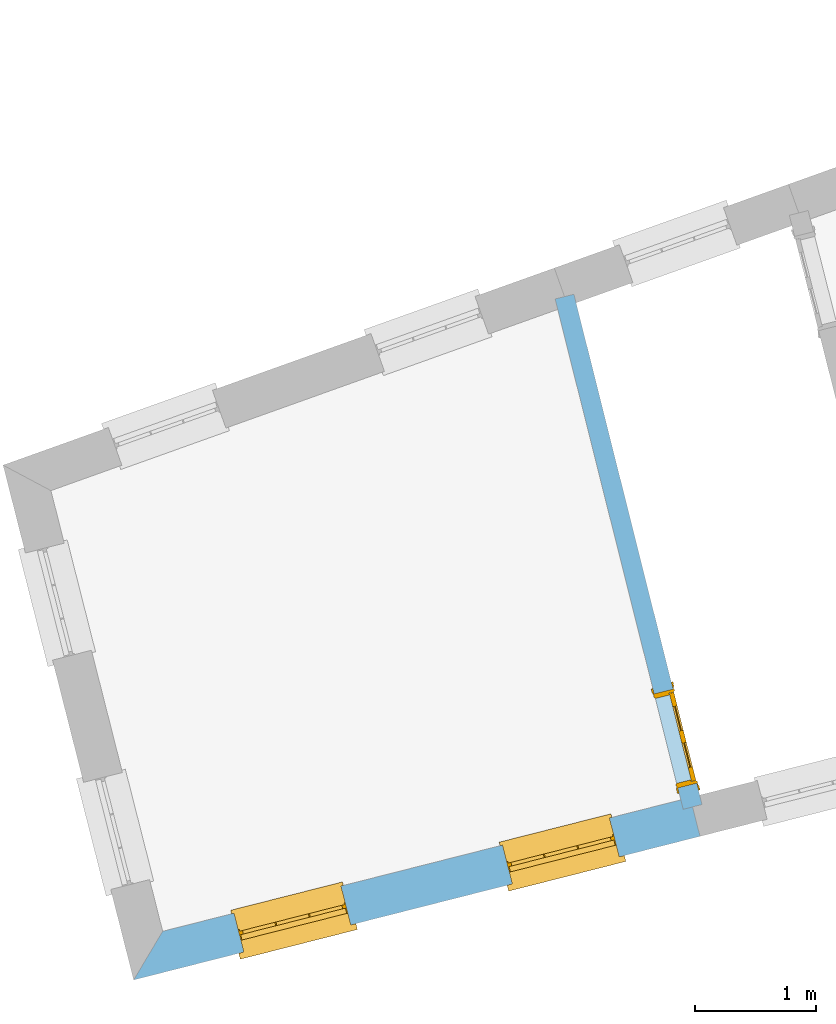
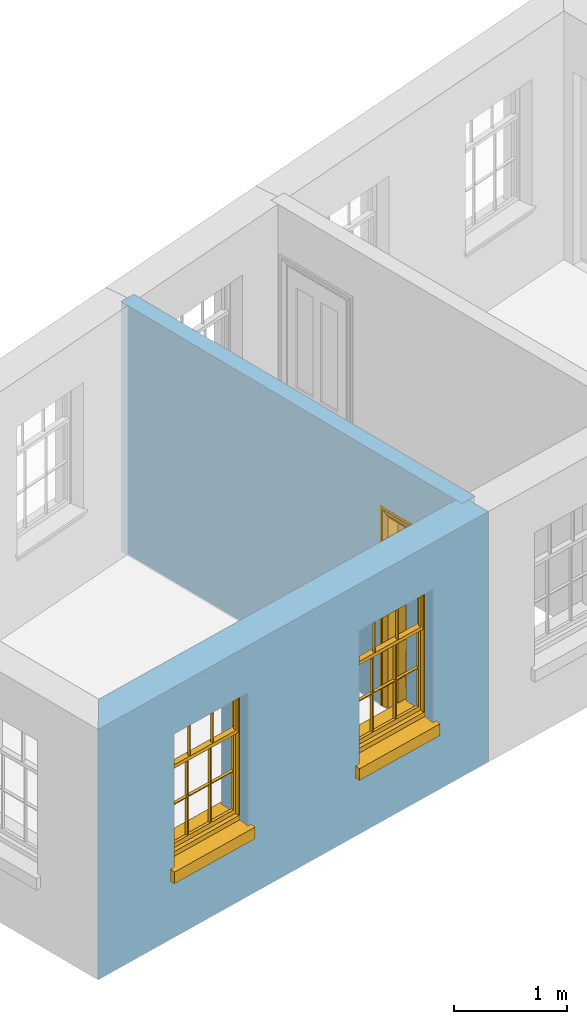
# One storey, part 3 of 10: 2 windows, 1 door, 3 openings, plus 2 elements that do not belong to this part.
"""IFC2X3 building model written with IfcOpenShell, lengths in metres."""

from ifc_helpers import new_model, si_unit, frame, origin, place, context, subcontext, project, spatial, polyline, outline, extrude, faceted_brep, material, layer, layer_set, layer_usage, element, fill, save


model = new_model("IFC2X3")

# Units and contexts
model_context = context("Model", 3, world=origin())
body_context = subcontext(model_context, "Body", "Model", "MODEL_VIEW")
ifc_project = project(units=[si_unit("PLANEANGLEUNIT", "RADIAN"), si_unit("MASSUNIT", "GRAM", prefix="KILO"), si_unit("FORCEUNIT", "NEWTON", prefix="KILO"), si_unit("LENGTHUNIT", "METRE")], contexts=[model_context])

# Site, building, storey
site_placement = place(None, origin())
site = spatial("IfcSite", under=ifc_project, at=site_placement, CompositionType="ELEMENT")
building_placement = place(None, origin())
building = spatial("IfcBuilding", under=site, at=building_placement, Name="Building plot-13", CompositionType="ELEMENT")
storey_placement = place(None, frame((0.0, 0.0, 9.55)))
storey = spatial("IfcBuildingStorey", under=building, at=storey_placement, Name="Floor 2", CompositionType="ELEMENT", Elevation=9.55)

# Wall, openings, windows
ifc_material_1 = material(Name="Masonry")
ifc_layer_1 = layer(ifc_material_1, 0.33, ventilated=False)
ifc_layer_set_1 = layer_set([ifc_layer_1], Name="My Wall")
ifc_layer_usage_1 = layer_usage(ifc_layer_set_1, "AXIS2", "NEGATIVE", 0.08)
wall_1_placement = place(storey_placement, origin())
wall_1 = element("IfcWallStandardCase", 1, at=wall_1_placement, inside=storey, material=ifc_layer_usage_1, Name="exterior", context=body_context, shape_type="SweptSolid", body=[
    extrude(outline(polyline([(66.8267058597151, 43.9122434030099), (66.5879619422004, 43.5112429767636), (71.2509007169492, 44.6938906600119), (71.1697724625834, 45.0137628318924), (66.8267058597151, 43.9122434030099)])), origin(), (0.0, 0.0, 1.0), 2.7),
])
opening_1_placement = place(storey_placement, frame((0.0, 0.0, 0.75)))
opening_1 = element("IfcOpeningElement", 2, at=opening_1_placement, cuts=wall_1, Name="Opening", ObjectType="Opening", context=body_context, shape_type="SweptSolid", body=[
    extrude(outline(polyline([(67.494406314742, 43.7411418429004), (68.3764780614428, 43.964859150394), (68.295349807077, 44.2847313222745), (67.4132780603762, 44.0610140147809), (67.494406314742, 43.7411418429004)])), origin(), (0.0, 0.0, 1.0), 1.445),
])
opening_2_placement = place(storey_placement, frame((0.0, 0.0, 0.75)))
opening_2 = element("IfcOpeningElement", 3, at=opening_2_placement, cuts=wall_1, Name="Opening", ObjectType="Opening", context=body_context, shape_type="SweptSolid", body=[
    extrude(outline(polyline([(69.7047120006465, 44.3017352851435), (70.5867837473473, 44.5254525926372), (70.5056554929815, 44.8453247645177), (69.6235837462807, 44.621607457024), (69.7047120006465, 44.3017352851435)])), origin(), (0.0, 0.0, 1.0), 1.445),
])
window_1_placement = place(storey_placement, frame((67.4329455159801, 43.9834692458402, 0.75), z_axis=(0.0, 0.0, 1.0), x_axis=(0.882071746700802, 0.223717307493636, 0.0)))
window_1 = element("IfcWindow", 4, at=window_1_placement, inside=storey, Name="bedroom outside window", OverallHeight=1.445, OverallWidth=0.91, context=body_context, shape_type="Brep", held_by="IfcProductRepresentation", body=[
    faceted_brep([(0.876875, -0.105, 0.999097), (0.876875, -0.105, 1.411875), (0.9, -0.105, 1.435), (0.033125, -0.105, 1.411875), (0.033125, -0.105, 0.999097), (0.01, -0.105, 1.435), (0.033125, -0.135, 1.411875), (0.01, -0.135, 1.435), (0.033125, -0.135, 0.999097), (0.876875, -0.135, 1.411875), (0.876875, -0.135, 0.999097), (0.9, -0.135, 1.435), (0.033125, -0.105, 0.960972), (0.01, -0.105, 0.960972), (0.033125, -0.105, 0.548195), (0.876875, -0.105, 0.960972), (0.876875, -0.105, 0.548195), (0.9, -0.105, 0.960972), (0.876875, -0.105, 0.538195), (0.876875, -0.105, 0.125417), (0.9, -0.105, 0.077167), (0.033125, -0.105, 0.125417), (0.033125, -0.105, 0.538195), (0.01, -0.105, 0.077167), (0.9, -0.135, 0.960972), (0.01, -0.135, 0.960972), (-0.0425, -0.25, 0.01), (-0.0425, -0.3, 0.001667), (0.0, -0.25, 0.01), (0.9525, -0.25, 0.01), (0.91, -0.25, 0.01), (0.9525, -0.3, 0.001667), (-0.02, 0.08, 0.077167), (0.0, 0.08, 0.077167), (-0.02, 0.11, 0.077167), (0.0, -0.06, 0.077167), (0.01, -0.06, 0.077167), (0.91, -0.06, 0.077167), (0.91, 0.08, 0.077167), (0.9, -0.06, 0.077167), (0.93, 0.08, 0.077167), (0.93, 0.11, 0.077167), (0.01, -0.105, 0.999097), (0.01, -0.075, 0.999097), (0.9, -0.105, 0.999097), (0.9, -0.075, 0.999097), (0.876875, -0.075, 0.125417), (0.876875, -0.075, 0.538195), (0.9, -0.075, 0.077167), (0.876875, -0.075, 0.548195), (0.876875, -0.075, 0.960972), (0.033125, -0.075, 0.125417), (0.01, -0.075, 0.077167), (0.033125, -0.075, 0.538195), (0.033125, -0.075, 0.960972), (0.033125, -0.075, 0.548195), (-0.02, 0.08, 0.052167), (-0.02, 0.11, 0.052167), (0.93, 0.11, 0.052167), (0.93, 0.08, 0.052167), (0.91, 0.08, 0.052167), (0.0, 0.08, 0.052167), (0.91, -0.15, 0.026667), (0.0, -0.15, 0.026667), (-0.0425, -0.3, -0.123333), (0.9525, -0.3, -0.123333), (-0.0425, -0.25, -0.123333), (0.9525, -0.25, -0.123333), (0.01, -0.06, 1.435), (0.9, -0.06, 1.435), (0.0, -0.06, 1.445), (0.91, -0.06, 1.445), (0.01, -0.15, 0.077167), (0.9, -0.15, 0.077167), (0.592292, -0.105, 0.125417), (0.592292, -0.075, 0.125417), (0.317708, -0.075, 0.125417), (0.317708, -0.105, 0.125417), (0.592292, -0.105, 0.548195), (0.317708, -0.105, 0.548195), (0.317708, -0.105, 0.538195), (0.592292, -0.105, 0.538195), (0.592292, -0.075, 0.548195), (0.317708, -0.075, 0.548195), (0.602292, -0.075, 0.548195), (0.602292, -0.105, 0.548195), (0.317708, -0.075, 0.538195), (0.307708, -0.075, 0.125417), (0.307708, -0.075, 0.538195), (0.602292, -0.075, 0.538195), (0.602292, -0.075, 0.125417), (0.592292, -0.075, 0.538195), (0.307708, -0.075, 0.548195), (0.317708, -0.075, 0.960972), (0.307708, -0.075, 0.960972), (0.602292, -0.075, 0.960972), (0.592292, -0.075, 0.960972), (0.307708, -0.105, 0.538195), (0.307708, -0.105, 0.125417), (0.307708, -0.105, 0.548195), (0.307708, -0.105, 0.960972), (0.592292, -0.105, 0.960972), (0.317708, -0.105, 0.960972), (0.602292, -0.105, 0.960972), (0.602292, -0.105, 0.538195), (0.602292, -0.105, 0.125417), (0.317708, -0.135, 1.411875), (0.307708, -0.135, 1.411875), (0.307708, -0.135, 0.999097), (0.317708, -0.135, 0.999097), (0.602292, -0.135, 1.411875), (0.592292, -0.135, 1.411875), (0.592292, -0.135, 0.999097), (0.602292, -0.135, 0.999097), (0.317708, -0.105, 0.999097), (0.307708, -0.105, 0.999097), (0.307708, -0.105, 1.411875), (0.317708, -0.105, 1.411875), (0.602292, -0.105, 0.999097), (0.592292, -0.105, 0.999097), (0.592292, -0.105, 1.411875), (0.602292, -0.105, 1.411875), (0.91, -0.15, 1.445), (0.9, -0.15, 1.435), (0.01, -0.15, 1.435), (0.0, -0.15, 1.445), (0.91, -0.25, 0.0), (0.0, -0.25, 0.0), (0.91, 0.08, 0.0), (0.0, 0.08, 0.0)], [[[0, 1, 2]], [[3, 4, 5]], [[6, 7, 8]], [[9, 10, 11]], [[12, 13, 14]], [[15, 16, 17]], [[18, 19, 20]], [[21, 22, 23]], [[24, 15, 17]], [[13, 12, 25]], [[26, 27, 28]], [[29, 30, 31]], [[32, 33, 34]], [[35, 36, 33]], [[37, 38, 39]], [[40, 41, 38]], [[42, 4, 43]], [[44, 45, 0]], [[46, 47, 48]], [[49, 50, 45]], [[51, 52, 53]], [[54, 55, 43]], [[38, 33, 36, 39]], [[41, 34, 33, 38]], [[56, 32, 34, 57]], [[57, 34, 41, 58]], [[58, 41, 40, 59]], [[57, 58, 60, 61]], [[52, 48, 39, 36]], [[62, 63, 28, 30]], [[27, 31, 30, 28]], [[27, 64, 65, 31]], [[66, 67, 65, 64]], [[2, 5, 68, 69]], [[68, 70, 71, 69]], [[20, 23, 72, 73]], [[73, 72, 63, 62]], [[74, 75, 76, 77]], [[78, 79, 80, 81]], [[78, 82, 83, 79]], [[16, 49, 84, 85]], [[86, 76, 87, 88]], [[89, 90, 75, 91]], [[92, 88, 53, 55]], [[82, 91, 86, 83]], [[93, 83, 92, 94]], [[95, 84, 82, 96]], [[89, 84, 49, 47]], [[97, 88, 87, 98]], [[22, 53, 88, 97]], [[81, 91, 75, 74]], [[80, 86, 91, 81]], [[77, 76, 86, 80]], [[99, 92, 55, 14]], [[100, 94, 92, 99]], [[101, 96, 82, 78]], [[79, 83, 93, 102]], [[85, 84, 95, 103]], [[104, 89, 47, 18]], [[105, 90, 89, 104]], [[104, 18, 16, 85]], [[80, 97, 98, 77]], [[104, 81, 74, 105]], [[103, 101, 78, 85]], [[99, 14, 22, 97]], [[102, 100, 99, 79]], [[106, 107, 108, 109]], [[110, 111, 112, 113]], [[114, 115, 116, 117]], [[118, 119, 120, 121]], [[107, 116, 115, 108]], [[111, 120, 119, 112]], [[109, 114, 117, 106]], [[113, 118, 121, 110]], [[85, 78, 81, 104]], [[84, 89, 91, 82]], [[83, 86, 88, 92]], [[79, 99, 97, 80]], [[109, 112, 119, 114]], [[102, 93, 96, 101]], [[106, 117, 120, 111]], [[98, 87, 51, 21]], [[6, 3, 116, 107]], [[110, 121, 1, 9]], [[19, 46, 90, 105]], [[26, 66, 64, 27]], [[29, 31, 65, 67]], [[25, 24, 112, 109]], [[11, 7, 106, 111]], [[75, 48, 52, 76]], [[43, 45, 96, 93]], [[45, 43, 114, 119]], [[5, 2, 120, 117]], [[24, 25, 102, 101]], [[42, 5, 4]], [[2, 44, 0]], [[49, 45, 48, 47]], [[52, 43, 55, 53]], [[14, 13, 23, 22]], [[20, 17, 16, 18]], [[24, 11, 10]], [[25, 8, 7]], [[8, 4, 3, 6]], [[9, 1, 0, 10]], [[15, 50, 49, 16]], [[18, 47, 46, 19]], [[21, 51, 53, 22]], [[14, 55, 54, 12]], [[44, 2, 69, 45]], [[68, 5, 42, 43]], [[36, 35, 70, 68]], [[39, 69, 71, 37]], [[62, 122, 123, 73]], [[63, 72, 124, 125]], [[8, 108, 115, 4]], [[113, 10, 0, 118]], [[94, 100, 12, 54]], [[17, 20, 73, 24]], [[72, 23, 13, 25]], [[52, 36, 68, 43]], [[69, 39, 48, 45]], [[11, 24, 73, 123]], [[7, 124, 72, 25]], [[23, 77, 98]], [[98, 21, 23]], [[105, 74, 20]], [[20, 19, 105]], [[20, 74, 77, 23]], [[113, 112, 24]], [[24, 10, 113]], [[25, 109, 108]], [[108, 8, 25]], [[110, 9, 11]], [[11, 111, 110]], [[7, 6, 107]], [[107, 106, 7]], [[5, 117, 116]], [[116, 3, 5]], [[121, 120, 2]], [[2, 1, 121]], [[11, 123, 124, 7]], [[122, 125, 124, 123]], [[43, 93, 94]], [[94, 54, 43]], [[96, 45, 95]], [[50, 95, 45]], [[15, 103, 95, 50]], [[48, 75, 90]], [[90, 46, 48]], [[87, 76, 52]], [[52, 51, 87]], [[103, 15, 24]], [[24, 101, 103]], [[100, 102, 25]], [[25, 12, 100]], [[115, 114, 43]], [[43, 4, 115]], [[118, 0, 45]], [[45, 119, 118]], [[71, 70, 125, 122]], [[70, 35, 63, 125]], [[122, 62, 37, 71]], [[126, 67, 66, 127]], [[60, 58, 59]], [[38, 60, 59, 40]], [[61, 56, 57]], [[32, 56, 61, 33]], [[61, 60, 128, 129]], [[62, 60, 38, 37]], [[126, 128, 60, 62]], [[33, 61, 63, 35]], [[61, 129, 127, 63]], [[128, 126, 127, 129]], [[28, 127, 66, 26]], [[63, 127, 28]], [[29, 67, 126, 30]], [[30, 126, 62]]]),
])
fill(opening_1, window_1)
window_2_placement = place(storey_placement, frame((69.6432512018846, 44.5440626880833, 0.75), z_axis=(0.0, 0.0, 1.0), x_axis=(0.882071746700802, 0.223717307493636, 0.0)))
window_2 = element("IfcWindow", 5, at=window_2_placement, inside=storey, Name="bedroom outside window", OverallHeight=1.445, OverallWidth=0.91, context=body_context, shape_type="Brep", held_by="IfcProductRepresentation", body=[
    faceted_brep([(0.876875, -0.105, 0.999097), (0.876875, -0.105, 1.411875), (0.9, -0.105, 1.435), (0.033125, -0.105, 1.411875), (0.033125, -0.105, 0.999097), (0.01, -0.105, 1.435), (0.033125, -0.135, 1.411875), (0.01, -0.135, 1.435), (0.033125, -0.135, 0.999097), (0.876875, -0.135, 1.411875), (0.876875, -0.135, 0.999097), (0.9, -0.135, 1.435), (0.033125, -0.105, 0.960972), (0.01, -0.105, 0.960972), (0.033125, -0.105, 0.548195), (0.876875, -0.105, 0.960972), (0.876875, -0.105, 0.548195), (0.9, -0.105, 0.960972), (0.876875, -0.105, 0.538195), (0.876875, -0.105, 0.125417), (0.9, -0.105, 0.077167), (0.033125, -0.105, 0.125417), (0.033125, -0.105, 0.538195), (0.01, -0.105, 0.077167), (0.9, -0.135, 0.960972), (0.01, -0.135, 0.960972), (-0.0425, -0.25, 0.01), (-0.0425, -0.3, 0.001667), (0.0, -0.25, 0.01), (0.9525, -0.25, 0.01), (0.91, -0.25, 0.01), (0.9525, -0.3, 0.001667), (-0.02, 0.08, 0.077167), (0.0, 0.08, 0.077167), (-0.02, 0.11, 0.077167), (0.0, -0.06, 0.077167), (0.01, -0.06, 0.077167), (0.91, -0.06, 0.077167), (0.91, 0.08, 0.077167), (0.9, -0.06, 0.077167), (0.93, 0.08, 0.077167), (0.93, 0.11, 0.077167), (0.01, -0.105, 0.999097), (0.01, -0.075, 0.999097), (0.9, -0.105, 0.999097), (0.9, -0.075, 0.999097), (0.876875, -0.075, 0.125417), (0.876875, -0.075, 0.538195), (0.9, -0.075, 0.077167), (0.876875, -0.075, 0.548195), (0.876875, -0.075, 0.960972), (0.033125, -0.075, 0.125417), (0.01, -0.075, 0.077167), (0.033125, -0.075, 0.538195), (0.033125, -0.075, 0.960972), (0.033125, -0.075, 0.548195), (-0.02, 0.08, 0.052167), (-0.02, 0.11, 0.052167), (0.93, 0.11, 0.052167), (0.93, 0.08, 0.052167), (0.91, 0.08, 0.052167), (0.0, 0.08, 0.052167), (0.91, -0.15, 0.026667), (0.0, -0.15, 0.026667), (-0.0425, -0.3, -0.123333), (0.9525, -0.3, -0.123333), (-0.0425, -0.25, -0.123333), (0.9525, -0.25, -0.123333), (0.01, -0.06, 1.435), (0.9, -0.06, 1.435), (0.0, -0.06, 1.445), (0.91, -0.06, 1.445), (0.01, -0.15, 0.077167), (0.9, -0.15, 0.077167), (0.592292, -0.105, 0.125417), (0.592292, -0.075, 0.125417), (0.317708, -0.075, 0.125417), (0.317708, -0.105, 0.125417), (0.592292, -0.105, 0.548195), (0.317708, -0.105, 0.548195), (0.317708, -0.105, 0.538195), (0.592292, -0.105, 0.538195), (0.592292, -0.075, 0.548195), (0.317708, -0.075, 0.548195), (0.602292, -0.075, 0.548195), (0.602292, -0.105, 0.548195), (0.317708, -0.075, 0.538195), (0.307708, -0.075, 0.125417), (0.307708, -0.075, 0.538195), (0.602292, -0.075, 0.538195), (0.602292, -0.075, 0.125417), (0.592292, -0.075, 0.538195), (0.307708, -0.075, 0.548195), (0.317708, -0.075, 0.960972), (0.307708, -0.075, 0.960972), (0.602292, -0.075, 0.960972), (0.592292, -0.075, 0.960972), (0.307708, -0.105, 0.538195), (0.307708, -0.105, 0.125417), (0.307708, -0.105, 0.548195), (0.307708, -0.105, 0.960972), (0.592292, -0.105, 0.960972), (0.317708, -0.105, 0.960972), (0.602292, -0.105, 0.960972), (0.602292, -0.105, 0.538195), (0.602292, -0.105, 0.125417), (0.317708, -0.135, 1.411875), (0.307708, -0.135, 1.411875), (0.307708, -0.135, 0.999097), (0.317708, -0.135, 0.999097), (0.602292, -0.135, 1.411875), (0.592292, -0.135, 1.411875), (0.592292, -0.135, 0.999097), (0.602292, -0.135, 0.999097), (0.317708, -0.105, 0.999097), (0.307708, -0.105, 0.999097), (0.307708, -0.105, 1.411875), (0.317708, -0.105, 1.411875), (0.602292, -0.105, 0.999097), (0.592292, -0.105, 0.999097), (0.592292, -0.105, 1.411875), (0.602292, -0.105, 1.411875), (0.91, -0.15, 1.445), (0.9, -0.15, 1.435), (0.01, -0.15, 1.435), (0.0, -0.15, 1.445), (0.91, -0.25, 0.0), (0.0, -0.25, 0.0), (0.91, 0.08, 0.0), (0.0, 0.08, 0.0)], [[[0, 1, 2]], [[3, 4, 5]], [[6, 7, 8]], [[9, 10, 11]], [[12, 13, 14]], [[15, 16, 17]], [[18, 19, 20]], [[21, 22, 23]], [[24, 15, 17]], [[13, 12, 25]], [[26, 27, 28]], [[29, 30, 31]], [[32, 33, 34]], [[35, 36, 33]], [[37, 38, 39]], [[40, 41, 38]], [[42, 4, 43]], [[44, 45, 0]], [[46, 47, 48]], [[49, 50, 45]], [[51, 52, 53]], [[54, 55, 43]], [[38, 33, 36, 39]], [[41, 34, 33, 38]], [[56, 32, 34, 57]], [[57, 34, 41, 58]], [[58, 41, 40, 59]], [[57, 58, 60, 61]], [[52, 48, 39, 36]], [[62, 63, 28, 30]], [[27, 31, 30, 28]], [[27, 64, 65, 31]], [[66, 67, 65, 64]], [[2, 5, 68, 69]], [[68, 70, 71, 69]], [[20, 23, 72, 73]], [[73, 72, 63, 62]], [[74, 75, 76, 77]], [[78, 79, 80, 81]], [[78, 82, 83, 79]], [[16, 49, 84, 85]], [[86, 76, 87, 88]], [[89, 90, 75, 91]], [[92, 88, 53, 55]], [[82, 91, 86, 83]], [[93, 83, 92, 94]], [[95, 84, 82, 96]], [[89, 84, 49, 47]], [[97, 88, 87, 98]], [[22, 53, 88, 97]], [[81, 91, 75, 74]], [[80, 86, 91, 81]], [[77, 76, 86, 80]], [[99, 92, 55, 14]], [[100, 94, 92, 99]], [[101, 96, 82, 78]], [[79, 83, 93, 102]], [[85, 84, 95, 103]], [[104, 89, 47, 18]], [[105, 90, 89, 104]], [[104, 18, 16, 85]], [[80, 97, 98, 77]], [[104, 81, 74, 105]], [[103, 101, 78, 85]], [[99, 14, 22, 97]], [[102, 100, 99, 79]], [[106, 107, 108, 109]], [[110, 111, 112, 113]], [[114, 115, 116, 117]], [[118, 119, 120, 121]], [[107, 116, 115, 108]], [[111, 120, 119, 112]], [[109, 114, 117, 106]], [[113, 118, 121, 110]], [[85, 78, 81, 104]], [[84, 89, 91, 82]], [[83, 86, 88, 92]], [[79, 99, 97, 80]], [[109, 112, 119, 114]], [[102, 93, 96, 101]], [[106, 117, 120, 111]], [[98, 87, 51, 21]], [[6, 3, 116, 107]], [[110, 121, 1, 9]], [[19, 46, 90, 105]], [[26, 66, 64, 27]], [[29, 31, 65, 67]], [[25, 24, 112, 109]], [[11, 7, 106, 111]], [[75, 48, 52, 76]], [[43, 45, 96, 93]], [[45, 43, 114, 119]], [[5, 2, 120, 117]], [[24, 25, 102, 101]], [[42, 5, 4]], [[2, 44, 0]], [[49, 45, 48, 47]], [[52, 43, 55, 53]], [[14, 13, 23, 22]], [[20, 17, 16, 18]], [[24, 11, 10]], [[25, 8, 7]], [[8, 4, 3, 6]], [[9, 1, 0, 10]], [[15, 50, 49, 16]], [[18, 47, 46, 19]], [[21, 51, 53, 22]], [[14, 55, 54, 12]], [[44, 2, 69, 45]], [[68, 5, 42, 43]], [[36, 35, 70, 68]], [[39, 69, 71, 37]], [[62, 122, 123, 73]], [[63, 72, 124, 125]], [[8, 108, 115, 4]], [[113, 10, 0, 118]], [[94, 100, 12, 54]], [[17, 20, 73, 24]], [[72, 23, 13, 25]], [[52, 36, 68, 43]], [[69, 39, 48, 45]], [[11, 24, 73, 123]], [[7, 124, 72, 25]], [[23, 77, 98]], [[98, 21, 23]], [[105, 74, 20]], [[20, 19, 105]], [[20, 74, 77, 23]], [[113, 112, 24]], [[24, 10, 113]], [[25, 109, 108]], [[108, 8, 25]], [[110, 9, 11]], [[11, 111, 110]], [[7, 6, 107]], [[107, 106, 7]], [[5, 117, 116]], [[116, 3, 5]], [[121, 120, 2]], [[2, 1, 121]], [[11, 123, 124, 7]], [[122, 125, 124, 123]], [[43, 93, 94]], [[94, 54, 43]], [[96, 45, 95]], [[50, 95, 45]], [[15, 103, 95, 50]], [[48, 75, 90]], [[90, 46, 48]], [[87, 76, 52]], [[52, 51, 87]], [[103, 15, 24]], [[24, 101, 103]], [[100, 102, 25]], [[25, 12, 100]], [[115, 114, 43]], [[43, 4, 115]], [[118, 0, 45]], [[45, 119, 118]], [[71, 70, 125, 122]], [[70, 35, 63, 125]], [[122, 62, 37, 71]], [[126, 67, 66, 127]], [[60, 58, 59]], [[38, 60, 59, 40]], [[61, 56, 57]], [[32, 56, 61, 33]], [[61, 60, 128, 129]], [[62, 60, 38, 37]], [[126, 128, 60, 62]], [[33, 61, 63, 35]], [[61, 129, 127, 63]], [[128, 126, 127, 129]], [[28, 127, 66, 26]], [[63, 127, 28]], [[29, 67, 126, 30]], [[30, 126, 62]]]),
])
fill(opening_2, window_2)

# Wall, opening, door
ifc_material_2 = material(Name="Masonry")
ifc_layer_2 = layer(ifc_material_2, 0.16, ventilated=False)
ifc_layer_set_2 = layer_set([ifc_layer_2], Name="My Wall")
ifc_layer_usage_2 = layer_usage(ifc_layer_set_2, "AXIS2", "NEGATIVE", 0.08)
wall_2_placement = place(storey_placement, origin())
wall_2 = element("IfcWallStandardCase", 6, at=wall_2_placement, inside=storey, material=ifc_layer_usage_2, Name="interior", context=body_context, shape_type="SweptSolid", body=[
    extrude(outline(polyline([(70.2128535545322, 49.1566719838343), (70.0576650175148, 49.1177294880441), (71.1118456496785, 44.9167468150566), (71.267034186696, 44.9556893108468), (70.2128535545322, 49.1566719838343)])), origin(), (0.0, 0.0, 1.0), 2.7),
])
opening_3_placement = place(storey_placement, frame((0.0, 0.0, 0.0199999999999996)))
opening_3 = element("IfcOpeningElement", 7, at=opening_3_placement, cuts=wall_2, Name="Opening", ObjectType="Opening", context=body_context, shape_type="SweptSolid", body=[
    extrude(outline(polyline([(70.8733228629633, 45.8672766042887), (71.0680353419145, 45.0913339192013), (71.2232238789319, 45.1302764149915), (71.0285113999808, 45.9062191000789), (70.8733228629633, 45.8672766042887)])), origin(), (0.0, 0.0, 1.0), 2.1),
])
door_placement = place(storey_placement, frame((70.950917131472, 45.8867478521838, 0.0199999999999996), z_axis=(0.0, 0.0, 1.0), x_axis=(0.194712478951175, -0.775942685087436, 0.0)))
door = element("IfcDoor", 8, at=door_placement, inside=storey, Name="bedroom inside door", OverallHeight=2.1, OverallWidth=0.8, context=body_context, shape_type="Brep", held_by="IfcProductRepresentation", body=[
    faceted_brep([(0.773, 0.08, 1.895), (0.66, 0.08, 1.895), (0.66, 0.08, 2.073), (0.773, 0.08, 2.073), (0.773, 0.08, 0.82), (0.66, 0.08, 0.82), (0.45, 0.08, 1.895), (0.45, 0.08, 2.073), (0.773, 0.08, 0.62), (0.66, 0.08, 0.62), (0.66, 0.065, 0.82), (0.66, 0.065, 1.895), (0.45, 0.065, 1.895), (0.35, 0.08, 1.895), (0.35, 0.08, 2.073), (0.773, 0.08, 0.225), (0.66, 0.08, 0.225), (0.45, 0.08, 0.62), (0.45, 0.08, 0.82), (0.45, 0.065, 0.82), (0.35, 0.08, 0.82), (0.14, 0.08, 2.073), (0.14, 0.08, 1.895), (0.773, 0.08, 0.0), (0.66, 0.08, 0.0), (0.66, 0.065, 0.225), (0.66, 0.065, 0.62), (0.45, 0.065, 0.62), (0.35, 0.08, 0.62), (0.35, 0.065, 0.82), (0.35, 0.065, 1.895), (0.14, 0.065, 1.895), (0.027, 0.08, 2.073), (0.027, 0.08, 1.895), (0.773, 0.042, 0.0), (0.66, 0.042, 0.0), (0.45, 0.08, 0.0), (0.45, 0.08, 0.225), (0.45, 0.065, 0.225), (0.35, 0.08, 0.225), (0.14, 0.08, 0.82), (0.14, 0.08, 0.62), (0.14, 0.065, 0.82), (0.027, 0.08, 0.82), (0.773, 0.042, 0.225), (0.66, 0.042, 0.225), (0.45, 0.042, 0.0), (0.35, 0.08, 0.0), (0.35, 0.065, 0.225), (0.35, 0.065, 0.62), (0.14, 0.065, 0.62), (0.027, 0.08, 0.62), (0.773, 0.042, 0.62), (0.66, 0.042, 0.62), (0.45, 0.042, 0.225), (0.35, 0.042, 0.0), (0.14, 0.08, 0.225), (0.14, 0.08, 0.0), (0.14, 0.065, 0.225), (0.027, 0.08, 0.225), (0.773, 0.042, 0.82), (0.66, 0.042, 0.82), (0.66, 0.057, 0.62), (0.66, 0.057, 0.225), (0.45, 0.057, 0.225), (0.35, 0.042, 0.225), (0.14, 0.042, 0.0), (0.027, 0.08, 0.0), (0.773, 0.042, 1.895), (0.66, 0.042, 1.895), (0.45, 0.042, 0.62), (0.45, 0.042, 0.82), (0.45, 0.057, 0.62), (0.35, 0.042, 0.62), (0.14, 0.042, 0.225), (0.027, 0.042, 0.0), (0.773, 0.042, 2.073), (0.66, 0.042, 2.073), (0.66, 0.057, 1.895), (0.66, 0.057, 0.82), (0.45, 0.057, 0.82), (0.35, 0.042, 0.82), (0.35, 0.057, 0.62), (0.35, 0.057, 0.225), (0.14, 0.057, 0.225), (0.027, 0.042, 0.225), (0.45, 0.042, 1.895), (0.45, 0.042, 2.073), (0.45, 0.057, 1.895), (0.35, 0.042, 1.895), (0.14, 0.042, 0.82), (0.14, 0.042, 0.62), (0.14, 0.057, 0.62), (0.027, 0.042, 0.62), (0.35, 0.042, 2.073), (0.35, 0.057, 1.895), (0.35, 0.057, 0.82), (0.14, 0.057, 0.82), (0.027, 0.042, 0.82), (0.14, 0.042, 2.073), (0.14, 0.042, 1.895), (0.14, 0.057, 1.895), (0.027, 0.042, 1.895), (0.027, 0.042, 2.073), (0.02, 0.085, 0.0), (0.005, 0.09, 0.0), (0.005, 0.09, 2.095), (0.02, 0.085, 2.08), (0.02, 0.08, 0.0), (0.0, 0.085, 0.0), (0.0, 0.085, 2.1), (0.795, 0.09, 2.095), (0.78, 0.085, 2.08), (0.02, 0.08, 2.08), (0.0, 0.08, 0.0), (-0.032, 0.095, 0.0), (-0.032, 0.095, 2.132), (0.8, 0.085, 2.1), (0.795, 0.09, 0.0), (0.78, 0.085, 0.0), (0.78, 0.08, 2.08), (0.04, 0.04, 0.0), (0.025, 0.04, 0.0), (0.025, 0.04, 2.075), (0.04, 0.04, 2.06), (-0.04, 0.09, 0.0), (-0.04, 0.09, 2.14), (0.832, 0.095, 2.132), (0.8, 0.085, 0.0), (0.78, 0.08, 0.0), (0.8, 0.08, 0.0), (0.86, 0.08, 0.0), (0.86, 0.08, 2.16), (0.8, 0.08, 2.1), (-0.06, 0.08, 2.16), (0.0, 0.08, 2.1), (-0.06, 0.08, 0.0), (-0.04, 0.095, 0.0), (-0.04, 0.095, 2.14), (0.84, 0.09, 2.14), (0.832, 0.095, 0.0), (0.84, 0.09, 0.0), (0.86, 0.095, 0.0), (0.86, 0.095, 2.16), (-0.06, 0.095, 2.16), (-0.06, 0.095, 0.0), (0.84, 0.095, 0.0), (0.84, 0.095, 2.14), (-0.025, -0.095, 0.0), (-0.025, -0.09, 0.0), (-0.025, -0.09, 2.125), (-0.025, -0.095, 2.125), (-0.017, -0.095, 0.0), (-0.017, -0.095, 2.117), (0.825, -0.09, 2.125), (0.825, -0.095, 2.125), (0.825, -0.095, 0.0), (0.845, -0.095, 0.0), (-0.045, -0.095, 2.145), (-0.045, -0.095, 0.0), (0.845, -0.095, 2.145), (0.015, -0.085, 0.0), (0.015, -0.085, 2.085), (0.817, -0.095, 2.117), (0.825, -0.09, 0.0), (0.845, -0.08, 0.0), (0.845, -0.08, 2.145), (-0.045, -0.08, 2.145), (-0.045, -0.08, 0.0), (0.02, -0.09, 0.0), (0.02, -0.09, 2.08), (0.785, -0.085, 2.085), (0.817, -0.095, 0.0), (0.8, -0.08, 0.0), (0.8, -0.08, 2.1), (0.0, -0.08, 2.1), (0.0, -0.08, 0.0), (0.035, -0.085, 0.0), (0.035, -0.085, 2.065), (0.78, -0.09, 2.08), (0.785, -0.085, 0.0), (0.775, 0.04, 2.075), (0.76, 0.04, 2.06), (0.035, -0.08, 2.065), (0.035, -0.08, 0.0), (0.765, -0.085, 2.065), (0.78, -0.09, 0.0), (0.765, -0.08, 0.0), (0.765, -0.08, 2.065), (0.765, -0.085, 0.0), (0.04, -0.08, 2.06), (0.04, -0.08, 0.0), (0.76, -0.08, 2.06), (0.76, -0.08, 0.0), (0.76, 0.04, 0.0), (0.775, 0.04, 0.0), (0.025, 0.08, 0.0), (0.025, 0.08, 2.075), (0.775, 0.08, 0.0), (0.775, 0.08, 2.075)], [[[0, 1, 2, 3]], [[1, 0, 4, 5]], [[1, 6, 7, 2]], [[8, 9, 5, 4]], [[1, 5, 10, 11]], [[6, 1, 11, 12]], [[6, 13, 14, 7]], [[15, 16, 9, 8]], [[9, 17, 18, 5]], [[5, 18, 19, 10]], [[10, 19, 12, 11]], [[18, 6, 12, 19]], [[18, 20, 13, 6]], [[21, 14, 13, 22]], [[23, 24, 16, 15]], [[9, 16, 25, 26]], [[17, 9, 26, 27]], [[17, 28, 20, 18]], [[13, 20, 29, 30]], [[22, 13, 30, 31]], [[32, 21, 22, 33]], [[34, 35, 24, 23]], [[24, 36, 37, 16]], [[16, 37, 38, 25]], [[25, 38, 27, 26]], [[37, 17, 27, 38]], [[37, 39, 28, 17]], [[40, 20, 28, 41]], [[20, 40, 42, 29]], [[31, 30, 29, 42]], [[40, 22, 31, 42]], [[33, 22, 40, 43]], [[35, 34, 44, 45]], [[35, 46, 36, 24]], [[36, 47, 39, 37]], [[28, 39, 48, 49]], [[41, 28, 49, 50]], [[43, 40, 41, 51]], [[45, 44, 52, 53]], [[46, 35, 45, 54]], [[46, 55, 47, 36]], [[56, 39, 47, 57]], [[39, 56, 58, 48]], [[50, 49, 48, 58]], [[56, 41, 50, 58]], [[51, 41, 56, 59]], [[53, 52, 60, 61]], [[45, 53, 62, 63]], [[54, 45, 63, 64]], [[55, 46, 54, 65]], [[55, 66, 57, 47]], [[59, 56, 57, 67]], [[61, 60, 68, 69]], [[70, 53, 61, 71]], [[53, 70, 72, 62]], [[72, 64, 63, 62]], [[70, 54, 64, 72]], [[65, 54, 70, 73]], [[65, 74, 66, 55]], [[67, 57, 66, 75]], [[69, 68, 76, 77]], [[61, 69, 78, 79]], [[71, 61, 79, 80]], [[73, 70, 71, 81]], [[65, 73, 82, 83]], [[74, 65, 83, 84]], [[74, 85, 75, 66]], [[86, 69, 77, 87]], [[69, 86, 88, 78]], [[88, 80, 79, 78]], [[86, 71, 80, 88]], [[81, 71, 86, 89]], [[73, 81, 90, 91]], [[73, 91, 92, 82]], [[83, 82, 92, 84]], [[91, 74, 84, 92]], [[91, 93, 85, 74]], [[89, 86, 87, 94]], [[81, 89, 95, 96]], [[90, 81, 96, 97]], [[90, 98, 93, 91]], [[94, 99, 100, 89]], [[89, 100, 101, 95]], [[101, 97, 96, 95]], [[100, 90, 97, 101]], [[100, 102, 98, 90]], [[99, 103, 102, 100]], [[32, 103, 99, 21]], [[102, 103, 32, 33]], [[98, 102, 33, 43]], [[21, 99, 94, 14]], [[94, 87, 7, 14]], [[7, 87, 77, 2]], [[76, 3, 2, 77]], [[43, 51, 93, 98]], [[51, 59, 85, 93]], [[67, 75, 85, 59]], [[34, 23, 15, 44]], [[44, 15, 8, 52]], [[52, 8, 4, 60]], [[0, 68, 60, 4]], [[0, 3, 76, 68]], [[104, 105, 106, 107]], [[104, 108, 109, 105]], [[105, 109, 110, 106]], [[107, 106, 111, 112]], [[107, 113, 108, 104]], [[114, 109, 108]], [[109, 115, 116, 110]], [[106, 110, 117, 111]], [[112, 111, 118, 119]], [[113, 107, 112, 120]], [[121, 122, 123, 124]], [[115, 109, 114, 125]], [[115, 125, 126, 116]], [[110, 116, 127, 117]], [[111, 117, 128, 118]], [[118, 128, 129, 119]], [[120, 112, 119, 129]], [[130, 129, 128]], [[130, 131, 132, 133]], [[133, 132, 134, 135]], [[135, 134, 136, 114]], [[136, 125, 114]], [[125, 137, 138, 126]], [[116, 126, 139, 127]], [[117, 127, 140, 128]], [[141, 130, 128, 140]], [[131, 130, 141]], [[131, 142, 143, 132]], [[132, 143, 144, 134]], [[134, 144, 145, 136]], [[137, 125, 136, 145]], [[143, 142, 146]], [[143, 146, 147]], [[137, 145, 144]], [[143, 147, 138]], [[138, 137, 144]], [[143, 138, 144]], [[126, 138, 147, 139]], [[127, 139, 141, 140]], [[142, 131, 141, 146]], [[139, 147, 146, 141]], [[148, 149, 150, 151]], [[149, 152, 153, 150]], [[151, 150, 154, 155]], [[155, 156, 157]], [[158, 159, 148]], [[158, 148, 151]], [[155, 157, 160]], [[158, 151, 155]], [[155, 160, 158]], [[152, 161, 162, 153]], [[150, 153, 163, 154]], [[155, 154, 164, 156]], [[156, 164, 165, 157]], [[157, 165, 166, 160]], [[160, 166, 167, 158]], [[158, 167, 168, 159]], [[161, 169, 170, 162]], [[153, 162, 171, 163]], [[154, 163, 172, 164]], [[165, 164, 173]], [[165, 173, 174, 166]], [[166, 174, 175, 167]], [[167, 175, 176, 168]], [[169, 177, 178, 170]], [[162, 170, 179, 171]], [[163, 171, 180, 172]], [[172, 180, 173, 164]], [[124, 123, 181, 182]], [[183, 178, 177, 184]], [[170, 178, 185, 179]], [[171, 179, 186, 180]], [[187, 173, 180]], [[185, 188, 187, 189]], [[188, 185, 178, 183]], [[179, 185, 189, 186]], [[189, 187, 180, 186]], [[190, 183, 184, 191]], [[192, 188, 183, 190]], [[191, 184, 122, 121]], [[124, 190, 191, 121]], [[193, 187, 188, 192]], [[182, 192, 190, 124]], [[184, 176, 122]], [[194, 195, 187, 193]], [[192, 182, 194, 193]], [[161, 176, 184]], [[114, 108, 122, 176]], [[173, 187, 195]], [[152, 149, 176, 161]], [[169, 161, 184, 177]], [[196, 122, 108]], [[176, 175, 135, 114]], [[173, 195, 129, 130]], [[176, 149, 168]], [[123, 122, 196, 197]], [[196, 108, 113, 197]], [[175, 174, 133, 135]], [[198, 129, 195]], [[133, 174, 173, 130]], [[159, 168, 149, 148]], [[181, 123, 197, 199]], [[197, 113, 120, 199]], [[199, 120, 129, 198]], [[195, 181, 199, 198]], [[195, 194, 182, 181]]]),
])
fill(opening_3, door)

save(model, "model.ifc")
